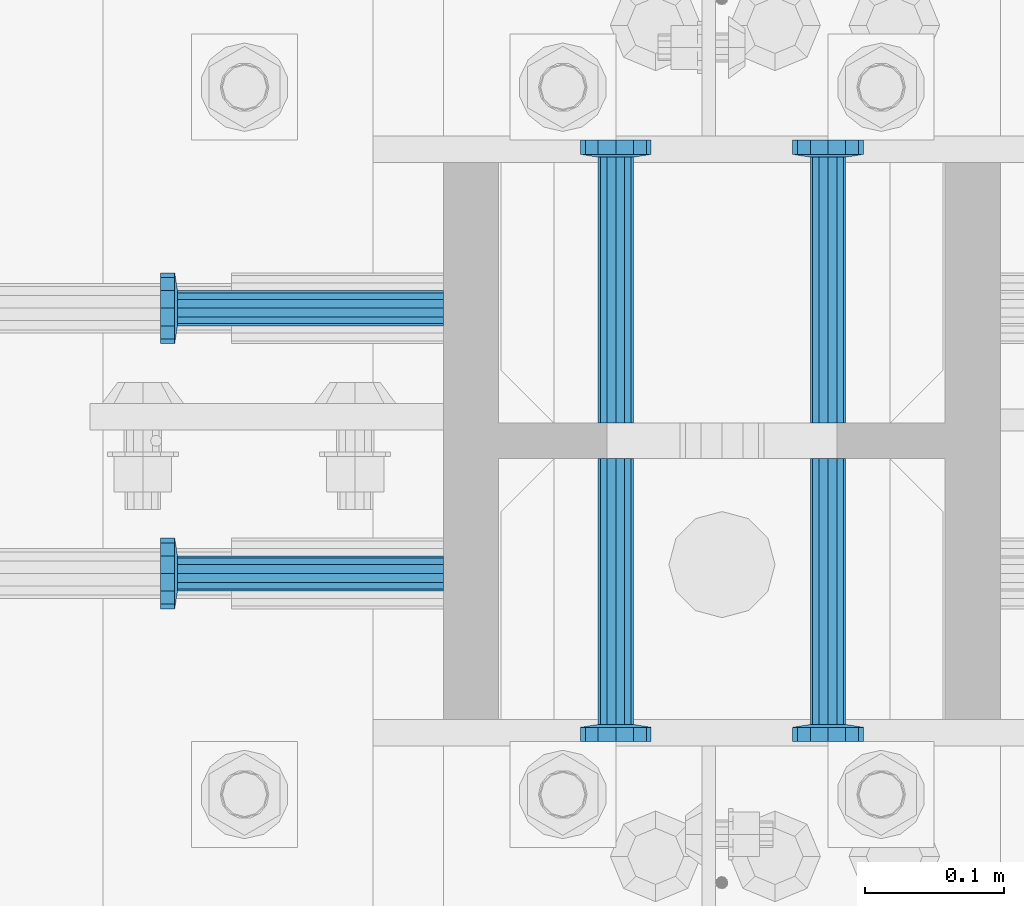
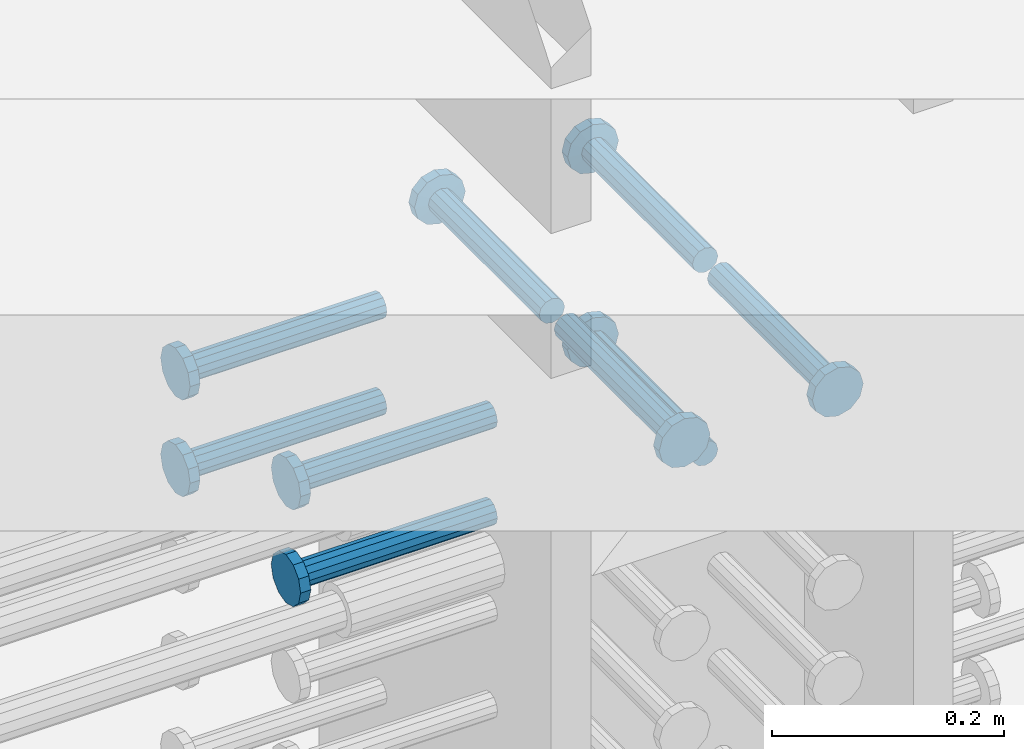
# One storey, part 1189 of 1763: 9 beams, 1 element without a shape of its own.
"""IFC2X3 building model written with IfcOpenShell, lengths in millimetres."""

from ifc_helpers import new_model, si_unit, frame, origin_with_axes, place, context, subcontext, project, spatial, faceted_brep, material, type_object, element, aggregate, save


model = new_model("IFC2X3")

# Units and contexts
model_context = context("Model", 3, precision=1e-05, world=origin_with_axes())
body_context = subcontext(model_context, "Body", "Model", "MODEL_VIEW")
ifc_project = project(units=[si_unit("LENGTHUNIT", "METRE", prefix="MILLI"), si_unit("AREAUNIT", "SQUARE_METRE"), si_unit("VOLUMEUNIT", "CUBIC_METRE"), si_unit("MASSUNIT", "GRAM", prefix="KILO"), si_unit("TIMEUNIT", "SECOND"), si_unit("PLANEANGLEUNIT", "RADIAN"), si_unit("SOLIDANGLEUNIT", "STERADIAN"), si_unit("THERMODYNAMICTEMPERATUREUNIT", "DEGREE_CELSIUS"), si_unit("LUMINOUSINTENSITYUNIT", "LUMEN")], contexts=[model_context])

# Site, building, storey
site_placement = place(None, origin_with_axes())
site = spatial("IfcSite", under=ifc_project, at=site_placement, CompositionType="ELEMENT")
building_placement = place(site_placement, origin_with_axes())
building = spatial("IfcBuilding", under=site, at=building_placement, Name="Undefined", CompositionType="ELEMENT")
storey_placement = place(building_placement, origin_with_axes())
storey = spatial("IfcBuildingStorey", under=building, at=storey_placement, Name="Undefined", CompositionType="ELEMENT", Elevation=0.0)

# Assembly, beams
assembly_placement = place(storey_placement, origin_with_axes())
assembly = element("IfcElementAssembly", 1, at=assembly_placement, inside=storey, Name="COLUMN", AssemblyPlace="NOTDEFINED", PredefinedType="RIGID_FRAME")
ifc_material = material(Name="STEEL/A108")
beam_type = type_object("IfcBeamType", PredefinedType="NOTDEFINED")
beam_1_placement = place(assembly_placement, frame((-72414.8374118345, 469.900000000843, 4927.60000000008), z_axis=(1.0, 0.0, 0.0), x_axis=(0.0, 1.0, 0.0)))
beam_1 = element("IfcBeam", 2, at=beam_1_placement, type_object=beam_type, material=ifc_material, Name="HEADED STUD ANCHOR", context=body_context, shape_type="Brep", body=[
    faceted_brep([(0.0, -12.6999999999971, -1.81898940354586e-12), (3.63797880709171e-12, -11.0, -6.34999990463257), (191.00799999576, -11.0, -6.34999990454889), (191.007999995752, -12.6999998092651, 8.36735125631094e-11), (7.27595761418343e-12, -6.34999990463257, -11.0), (191.00799999576, -6.34999990463257, -10.9999999999163), (3.63797880709171e-12, 0.0, -12.6999998092651), (191.00799999576, 0.0, -12.6999998091815), (7.27595761418343e-12, 6.34999990463257, -11.0), (191.00799999576, 6.34999990463257, -10.9999999999163), (3.63797880709171e-12, 11.0, -6.34999990463257), (191.00799999576, 11.0, -6.34999990454889), (0.0, 12.6999999999971, -1.81898940354586e-12), (191.007999995752, 12.6999998092651, 8.36735125631094e-11), (0.0, 11.0, 6.34999990463257), (191.007999995752, 11.0, 6.34999990471624), (-3.63797880709171e-12, 6.34999990463257, 11.0), (191.007999995749, 6.34999990463257, 11.0000000000837), (-3.63797880709171e-12, 0.0, 12.6999998092651), (191.007999995749, 0.0, 12.6999998093488), (-3.63797880709171e-12, -6.34999990463257, 11.0), (191.007999995749, -6.34999990463257, 11.0000000000837), (0.0, -11.0, 6.34999990463257), (191.007999995752, -11.0, 6.34999990471624), (193.039999995715, -22.0, -12.6999998091796), (193.039999995708, -25.3999996185303, 8.54925019666553e-11), (193.039999995719, -12.6999998092651, -21.9999999999145), (193.039999995719, 0.0, -25.3999996184448), (193.039999995719, 12.6999998092651, -21.9999999999145), (193.039999995715, 22.0, -12.6999998091796), (193.039999995708, 25.3999996185303, 8.54925019666553e-11), (193.039999995704, 22.0, 12.6999998093506), (193.039999995701, 12.6999998092651, 22.0000000000855), (193.039999995697, 0.0, 25.3999996186158), (193.039999995701, -12.6999998092651, 22.0000000000855), (193.039999995704, -22.0, 12.6999998093506), (203.199999995486, -22.0, -12.6999998091742), (203.199999995482, -25.3999996185303, 9.09494701772928e-11), (203.199999995493, -12.6999998092651, -21.9999999999091), (203.199999995493, 0.0, -25.3999996184393), (203.199999995493, 12.6999998092651, -21.9999999999091), (203.199999995486, 22.0, -12.6999998091742), (203.199999995482, 25.3999996185303, 9.09494701772928e-11), (203.199999995479, 22.0, 12.6999998093561), (203.199999995475, 12.6999998092651, 22.0000000000909), (203.199999995471, 0.0, 25.3999996186212), (203.199999995475, -12.6999998092651, 22.0000000000909), (203.199999995479, -22.0, 12.6999998093561)], [[[0, 1, 2, 3]], [[1, 4, 5, 2]], [[4, 6, 7, 5]], [[6, 8, 9, 7]], [[8, 10, 11, 9]], [[10, 12, 13, 11]], [[12, 14, 15, 13]], [[14, 16, 17, 15]], [[16, 18, 19, 17]], [[18, 20, 21, 19]], [[20, 22, 23, 21]], [[22, 0, 3, 23]], [[22, 20, 18, 16, 14, 12, 10, 8, 6, 4, 1, 0]], [[3, 2, 24, 25]], [[2, 5, 26, 24]], [[5, 7, 27, 26]], [[7, 9, 28, 27]], [[9, 11, 29, 28]], [[11, 13, 30, 29]], [[13, 15, 31, 30]], [[15, 17, 32, 31]], [[17, 19, 33, 32]], [[19, 21, 34, 33]], [[21, 23, 35, 34]], [[23, 3, 25, 35]], [[25, 24, 36, 37]], [[24, 26, 38, 36]], [[26, 27, 39, 38]], [[27, 28, 40, 39]], [[28, 29, 41, 40]], [[29, 30, 42, 41]], [[30, 31, 43, 42]], [[31, 32, 44, 43]], [[32, 33, 45, 44]], [[33, 34, 46, 45]], [[34, 35, 47, 46]], [[35, 25, 37, 47]], [[38, 39, 40, 41, 42, 43, 44, 45, 46, 47, 37, 36]]]),
])
beam_2_placement = place(assembly_placement, frame((-72567.2374118343, 469.899999003702, 4927.60000000008), z_axis=(1.0, 0.0, 0.0), x_axis=(0.0, 1.0, 0.0)))
beam_2 = element("IfcBeam", 3, at=beam_2_placement, type_object=beam_type, material=ifc_material, Name="HEADED STUD ANCHOR", context=body_context, shape_type="Brep", body=[
    faceted_brep([(0.0, -12.6999999999971, -1.81898940354586e-12), (3.63797880709171e-12, -11.0, -6.34999990463257), (191.00799999576, -11.0, -6.34999990454889), (191.007999995752, -12.6999998092651, 8.36735125631094e-11), (7.27595761418343e-12, -6.34999990463257, -11.0), (191.00799999576, -6.34999990463257, -10.9999999999163), (3.63797880709171e-12, 0.0, -12.6999998092651), (191.00799999576, 0.0, -12.6999998091815), (7.27595761418343e-12, 6.34999990463257, -11.0), (191.00799999576, 6.34999990463257, -10.9999999999163), (3.63797880709171e-12, 11.0, -6.34999990463257), (191.00799999576, 11.0, -6.34999990454889), (0.0, 12.6999999999971, -1.81898940354586e-12), (191.007999995752, 12.6999998092651, 8.36735125631094e-11), (0.0, 11.0, 6.34999990463257), (191.007999995752, 11.0, 6.34999990471624), (-3.63797880709171e-12, 6.34999990463257, 11.0), (191.007999995749, 6.34999990463257, 11.0000000000837), (-3.63797880709171e-12, 0.0, 12.6999998092651), (191.007999995749, 0.0, 12.6999998093488), (-3.63797880709171e-12, -6.34999990463257, 11.0), (191.007999995749, -6.34999990463257, 11.0000000000837), (0.0, -11.0, 6.34999990463257), (191.007999995752, -11.0, 6.34999990471624), (193.039999995715, -22.0, -12.6999998091796), (193.039999995708, -25.3999996185303, 8.54925019666553e-11), (193.039999995719, -12.6999998092651, -21.9999999999145), (193.039999995719, 0.0, -25.3999996184448), (193.039999995719, 12.6999998092651, -21.9999999999145), (193.039999995715, 22.0, -12.6999998091796), (193.039999995708, 25.3999996185303, 8.54925019666553e-11), (193.039999995704, 22.0, 12.6999998093506), (193.039999995701, 12.6999998092651, 22.0000000000855), (193.039999995697, 0.0, 25.3999996186158), (193.039999995701, -12.6999998092651, 22.0000000000855), (193.039999995704, -22.0, 12.6999998093506), (203.199999995486, -22.0, -12.6999998091742), (203.199999995482, -25.3999996185303, 9.09494701772928e-11), (203.199999995493, -12.6999998092651, -21.9999999999091), (203.199999995493, 0.0, -25.3999996184393), (203.199999995493, 12.6999998092651, -21.9999999999091), (203.199999995486, 22.0, -12.6999998091742), (203.199999995482, 25.3999996185303, 9.09494701772928e-11), (203.199999995479, 22.0, 12.6999998093561), (203.199999995475, 12.6999998092651, 22.0000000000909), (203.199999995471, 0.0, 25.3999996186212), (203.199999995475, -12.6999998092651, 22.0000000000909), (203.199999995479, -22.0, 12.6999998093561)], [[[0, 1, 2, 3]], [[1, 4, 5, 2]], [[4, 6, 7, 5]], [[6, 8, 9, 7]], [[8, 10, 11, 9]], [[10, 12, 13, 11]], [[12, 14, 15, 13]], [[14, 16, 17, 15]], [[16, 18, 19, 17]], [[18, 20, 21, 19]], [[20, 22, 23, 21]], [[22, 0, 3, 23]], [[22, 20, 18, 16, 14, 12, 10, 8, 6, 4, 1, 0]], [[3, 2, 24, 25]], [[2, 5, 26, 24]], [[5, 7, 27, 26]], [[7, 9, 28, 27]], [[9, 11, 29, 28]], [[11, 13, 30, 29]], [[13, 15, 31, 30]], [[15, 17, 32, 31]], [[17, 19, 33, 32]], [[19, 21, 34, 33]], [[21, 23, 35, 34]], [[23, 3, 25, 35]], [[25, 24, 36, 37]], [[24, 26, 38, 36]], [[26, 27, 39, 38]], [[27, 28, 40, 39]], [[28, 29, 41, 40]], [[29, 30, 42, 41]], [[30, 31, 43, 42]], [[31, 32, 44, 43]], [[32, 33, 45, 44]], [[33, 34, 46, 45]], [[34, 35, 47, 46]], [[35, 25, 37, 47]], [[38, 39, 40, 41, 42, 43, 44, 45, 46, 47, 37, 36]]]),
])
beam_3_placement = place(assembly_placement, frame((-72691.0622736972, 552.45000000066, 4927.60000000008), z_axis=(0.0, 1.0, 0.0), x_axis=(-1.0, 0.0, 0.0)))
beam_3 = element("IfcBeam", 4, at=beam_3_placement, type_object=beam_type, material=ifc_material, Name="HEADED STUD ANCHOR", context=body_context, shape_type="Brep", body=[
    faceted_brep([(0.0, -12.6999999999971, -1.81898940354586e-12), (3.63797880709171e-12, -11.0, -6.34999990463257), (191.00799999576, -11.0, -6.34999990454889), (191.007999995752, -12.6999998092651, 8.36735125631094e-11), (7.27595761418343e-12, -6.34999990463257, -11.0), (191.00799999576, -6.34999990463257, -10.9999999999163), (3.63797880709171e-12, 0.0, -12.6999998092651), (191.00799999576, 0.0, -12.6999998091815), (7.27595761418343e-12, 6.34999990463257, -11.0), (191.00799999576, 6.34999990463257, -10.9999999999163), (3.63797880709171e-12, 11.0, -6.34999990463257), (191.00799999576, 11.0, -6.34999990454889), (0.0, 12.6999999999971, -1.81898940354586e-12), (191.007999995752, 12.6999998092651, 8.36735125631094e-11), (0.0, 11.0, 6.34999990463257), (191.007999995752, 11.0, 6.34999990471624), (-3.63797880709171e-12, 6.34999990463257, 11.0), (191.007999995749, 6.34999990463257, 11.0000000000837), (-3.63797880709171e-12, 0.0, 12.6999998092651), (191.007999995749, 0.0, 12.6999998093488), (-3.63797880709171e-12, -6.34999990463257, 11.0), (191.007999995749, -6.34999990463257, 11.0000000000837), (0.0, -11.0, 6.34999990463257), (191.007999995752, -11.0, 6.34999990471624), (193.039999995715, -22.0, -12.6999998091796), (193.039999995708, -25.3999996185303, 8.54925019666553e-11), (193.039999995719, -12.6999998092651, -21.9999999999145), (193.039999995719, 0.0, -25.3999996184448), (193.039999995719, 12.6999998092651, -21.9999999999145), (193.039999995715, 22.0, -12.6999998091796), (193.039999995708, 25.3999996185303, 8.54925019666553e-11), (193.039999995704, 22.0, 12.6999998093506), (193.039999995701, 12.6999998092651, 22.0000000000855), (193.039999995697, 0.0, 25.3999996186158), (193.039999995701, -12.6999998092651, 22.0000000000855), (193.039999995704, -22.0, 12.6999998093506), (203.199999995486, -22.0, -12.6999998091742), (203.199999995482, -25.3999996185303, 9.09494701772928e-11), (203.199999995493, -12.6999998092651, -21.9999999999091), (203.199999995493, 0.0, -25.3999996184393), (203.199999995493, 12.6999998092651, -21.9999999999091), (203.199999995486, 22.0, -12.6999998091742), (203.199999995482, 25.3999996185303, 9.09494701772928e-11), (203.199999995479, 22.0, 12.6999998093561), (203.199999995475, 12.6999998092651, 22.0000000000909), (203.199999995471, 0.0, 25.3999996186212), (203.199999995475, -12.6999998092651, 22.0000000000909), (203.199999995479, -22.0, 12.6999998093561)], [[[0, 1, 2, 3]], [[1, 4, 5, 2]], [[4, 6, 7, 5]], [[6, 8, 9, 7]], [[8, 10, 11, 9]], [[10, 12, 13, 11]], [[12, 14, 15, 13]], [[14, 16, 17, 15]], [[16, 18, 19, 17]], [[18, 20, 21, 19]], [[20, 22, 23, 21]], [[22, 0, 3, 23]], [[22, 20, 18, 16, 14, 12, 10, 8, 6, 4, 1, 0]], [[3, 2, 24, 25]], [[2, 5, 26, 24]], [[5, 7, 27, 26]], [[7, 9, 28, 27]], [[9, 11, 29, 28]], [[11, 13, 30, 29]], [[13, 15, 31, 30]], [[15, 17, 32, 31]], [[17, 19, 33, 32]], [[19, 21, 34, 33]], [[21, 23, 35, 34]], [[23, 3, 25, 35]], [[25, 24, 36, 37]], [[24, 26, 38, 36]], [[26, 27, 39, 38]], [[27, 28, 40, 39]], [[28, 29, 41, 40]], [[29, 30, 42, 41]], [[30, 31, 43, 42]], [[31, 32, 44, 43]], [[32, 33, 45, 44]], [[33, 34, 46, 45]], [[34, 35, 47, 46]], [[35, 25, 37, 47]], [[38, 39, 40, 41, 42, 43, 44, 45, 46, 47, 37, 36]]]),
])
beam_4_placement = place(assembly_placement, frame((-72691.0623424328, 361.950000000834, 4927.60000000008), z_axis=(0.0, 1.0, 0.0), x_axis=(-1.0, 0.0, 0.0)))
beam_4 = element("IfcBeam", 5, at=beam_4_placement, type_object=beam_type, material=ifc_material, Name="HEADED STUD ANCHOR", context=body_context, shape_type="Brep", body=[
    faceted_brep([(0.0, -12.6999999999971, -1.81898940354586e-12), (3.63797880709171e-12, -11.0, -6.34999990463257), (191.00799999576, -11.0, -6.34999990454889), (191.007999995752, -12.6999998092651, 8.36735125631094e-11), (7.27595761418343e-12, -6.34999990463257, -11.0), (191.00799999576, -6.34999990463257, -10.9999999999163), (3.63797880709171e-12, 0.0, -12.6999998092651), (191.00799999576, 0.0, -12.6999998091815), (7.27595761418343e-12, 6.34999990463257, -11.0), (191.00799999576, 6.34999990463257, -10.9999999999163), (3.63797880709171e-12, 11.0, -6.34999990463257), (191.00799999576, 11.0, -6.34999990454889), (0.0, 12.6999999999971, -1.81898940354586e-12), (191.007999995752, 12.6999998092651, 8.36735125631094e-11), (0.0, 11.0, 6.34999990463257), (191.007999995752, 11.0, 6.34999990471624), (-3.63797880709171e-12, 6.34999990463257, 11.0), (191.007999995749, 6.34999990463257, 11.0000000000837), (-3.63797880709171e-12, 0.0, 12.6999998092651), (191.007999995749, 0.0, 12.6999998093488), (-3.63797880709171e-12, -6.34999990463257, 11.0), (191.007999995749, -6.34999990463257, 11.0000000000837), (0.0, -11.0, 6.34999990463257), (191.007999995752, -11.0, 6.34999990471624), (193.039999995715, -22.0, -12.6999998091796), (193.039999995708, -25.3999996185303, 8.54925019666553e-11), (193.039999995719, -12.6999998092651, -21.9999999999145), (193.039999995719, 0.0, -25.3999996184448), (193.039999995719, 12.6999998092651, -21.9999999999145), (193.039999995715, 22.0, -12.6999998091796), (193.039999995708, 25.3999996185303, 8.54925019666553e-11), (193.039999995704, 22.0, 12.6999998093506), (193.039999995701, 12.6999998092651, 22.0000000000855), (193.039999995697, 0.0, 25.3999996186158), (193.039999995701, -12.6999998092651, 22.0000000000855), (193.039999995704, -22.0, 12.6999998093506), (203.199999995486, -22.0, -12.6999998091742), (203.199999995482, -25.3999996185303, 9.09494701772928e-11), (203.199999995493, -12.6999998092651, -21.9999999999091), (203.199999995493, 0.0, -25.3999996184393), (203.199999995493, 12.6999998092651, -21.9999999999091), (203.199999995486, 22.0, -12.6999998091742), (203.199999995482, 25.3999996185303, 9.09494701772928e-11), (203.199999995479, 22.0, 12.6999998093561), (203.199999995475, 12.6999998092651, 22.0000000000909), (203.199999995471, 0.0, 25.3999996186212), (203.199999995475, -12.6999998092651, 22.0000000000909), (203.199999995479, -22.0, 12.6999998093561)], [[[0, 1, 2, 3]], [[1, 4, 5, 2]], [[4, 6, 7, 5]], [[6, 8, 9, 7]], [[8, 10, 11, 9]], [[10, 12, 13, 11]], [[12, 14, 15, 13]], [[14, 16, 17, 15]], [[16, 18, 19, 17]], [[18, 20, 21, 19]], [[20, 22, 23, 21]], [[22, 0, 3, 23]], [[22, 20, 18, 16, 14, 12, 10, 8, 6, 4, 1, 0]], [[3, 2, 24, 25]], [[2, 5, 26, 24]], [[5, 7, 27, 26]], [[7, 9, 28, 27]], [[9, 11, 29, 28]], [[11, 13, 30, 29]], [[13, 15, 31, 30]], [[15, 17, 32, 31]], [[17, 19, 33, 32]], [[19, 21, 34, 33]], [[21, 23, 35, 34]], [[23, 3, 25, 35]], [[25, 24, 36, 37]], [[24, 26, 38, 36]], [[26, 27, 39, 38]], [[27, 28, 40, 39]], [[28, 29, 41, 40]], [[29, 30, 42, 41]], [[30, 31, 43, 42]], [[31, 32, 44, 43]], [[32, 33, 45, 44]], [[33, 34, 46, 45]], [[34, 35, 47, 46]], [[35, 25, 37, 47]], [[38, 39, 40, 41, 42, 43, 44, 45, 46, 47, 37, 36]]]),
])
beam_5_placement = place(assembly_placement, frame((-72567.2374108258, 444.499999886566, 4927.60000000008), z_axis=(1.0, 0.0, 0.0), x_axis=(0.0, -1.0, 0.0)))
beam_5 = element("IfcBeam", 6, at=beam_5_placement, type_object=beam_type, material=ifc_material, Name="HEADED STUD ANCHOR", context=body_context, shape_type="Brep", body=[
    faceted_brep([(0.0, -12.6999999999971, -1.81898940354586e-12), (3.63797880709171e-12, -11.0, -6.34999990463257), (191.00799999576, -11.0, -6.34999990454889), (191.007999995752, -12.6999998092651, 8.36735125631094e-11), (7.27595761418343e-12, -6.34999990463257, -11.0), (191.00799999576, -6.34999990463257, -10.9999999999163), (3.63797880709171e-12, 0.0, -12.6999998092651), (191.00799999576, 0.0, -12.6999998091815), (7.27595761418343e-12, 6.34999990463257, -11.0), (191.00799999576, 6.34999990463257, -10.9999999999163), (3.63797880709171e-12, 11.0, -6.34999990463257), (191.00799999576, 11.0, -6.34999990454889), (0.0, 12.6999999999971, -1.81898940354586e-12), (191.007999995752, 12.6999998092651, 8.36735125631094e-11), (0.0, 11.0, 6.34999990463257), (191.007999995752, 11.0, 6.34999990471624), (-3.63797880709171e-12, 6.34999990463257, 11.0), (191.007999995749, 6.34999990463257, 11.0000000000837), (-3.63797880709171e-12, 0.0, 12.6999998092651), (191.007999995749, 0.0, 12.6999998093488), (-3.63797880709171e-12, -6.34999990463257, 11.0), (191.007999995749, -6.34999990463257, 11.0000000000837), (0.0, -11.0, 6.34999990463257), (191.007999995752, -11.0, 6.34999990471624), (193.039999995715, -22.0, -12.6999998091796), (193.039999995708, -25.3999996185303, 8.54925019666553e-11), (193.039999995719, -12.6999998092651, -21.9999999999145), (193.039999995719, 0.0, -25.3999996184448), (193.039999995719, 12.6999998092651, -21.9999999999145), (193.039999995715, 22.0, -12.6999998091796), (193.039999995708, 25.3999996185303, 8.54925019666553e-11), (193.039999995704, 22.0, 12.6999998093506), (193.039999995701, 12.6999998092651, 22.0000000000855), (193.039999995697, 0.0, 25.3999996186158), (193.039999995701, -12.6999998092651, 22.0000000000855), (193.039999995704, -22.0, 12.6999998093506), (203.199999995486, -22.0, -12.6999998091742), (203.199999995482, -25.3999996185303, 9.09494701772928e-11), (203.199999995493, -12.6999998092651, -21.9999999999091), (203.199999995493, 0.0, -25.3999996184393), (203.199999995493, 12.6999998092651, -21.9999999999091), (203.199999995486, 22.0, -12.6999998091742), (203.199999995482, 25.3999996185303, 9.09494701772928e-11), (203.199999995479, 22.0, 12.6999998093561), (203.199999995475, 12.6999998092651, 22.0000000000909), (203.199999995471, 0.0, 25.3999996186212), (203.199999995475, -12.6999998092651, 22.0000000000909), (203.199999995479, -22.0, 12.6999998093561)], [[[0, 1, 2, 3]], [[1, 4, 5, 2]], [[4, 6, 7, 5]], [[6, 8, 9, 7]], [[8, 10, 11, 9]], [[10, 12, 13, 11]], [[12, 14, 15, 13]], [[14, 16, 17, 15]], [[16, 18, 19, 17]], [[18, 20, 21, 19]], [[20, 22, 23, 21]], [[22, 0, 3, 23]], [[22, 20, 18, 16, 14, 12, 10, 8, 6, 4, 1, 0]], [[3, 2, 24, 25]], [[2, 5, 26, 24]], [[5, 7, 27, 26]], [[7, 9, 28, 27]], [[9, 11, 29, 28]], [[11, 13, 30, 29]], [[13, 15, 31, 30]], [[15, 17, 32, 31]], [[17, 19, 33, 32]], [[19, 21, 34, 33]], [[21, 23, 35, 34]], [[23, 3, 25, 35]], [[25, 24, 36, 37]], [[24, 26, 38, 36]], [[26, 27, 39, 38]], [[27, 28, 40, 39]], [[28, 29, 41, 40]], [[29, 30, 42, 41]], [[30, 31, 43, 42]], [[31, 32, 44, 43]], [[32, 33, 45, 44]], [[33, 34, 46, 45]], [[34, 35, 47, 46]], [[35, 25, 37, 47]], [[38, 39, 40, 41, 42, 43, 44, 45, 46, 47, 37, 36]]]),
])
beam_6_placement = place(assembly_placement, frame((-72414.8374108267, 444.500000000843, 4927.60000000008), z_axis=(1.0, 0.0, 0.0), x_axis=(0.0, -1.0, 0.0)))
beam_6 = element("IfcBeam", 7, at=beam_6_placement, type_object=beam_type, material=ifc_material, Name="HEADED STUD ANCHOR", context=body_context, shape_type="Brep", body=[
    faceted_brep([(0.0, -12.6999999999971, -1.81898940354586e-12), (3.63797880709171e-12, -11.0, -6.34999990463257), (191.00799999576, -11.0, -6.34999990454889), (191.007999995752, -12.6999998092651, 8.36735125631094e-11), (7.27595761418343e-12, -6.34999990463257, -11.0), (191.00799999576, -6.34999990463257, -10.9999999999163), (3.63797880709171e-12, 0.0, -12.6999998092651), (191.00799999576, 0.0, -12.6999998091815), (7.27595761418343e-12, 6.34999990463257, -11.0), (191.00799999576, 6.34999990463257, -10.9999999999163), (3.63797880709171e-12, 11.0, -6.34999990463257), (191.00799999576, 11.0, -6.34999990454889), (0.0, 12.6999999999971, -1.81898940354586e-12), (191.007999995752, 12.6999998092651, 8.36735125631094e-11), (0.0, 11.0, 6.34999990463257), (191.007999995752, 11.0, 6.34999990471624), (-3.63797880709171e-12, 6.34999990463257, 11.0), (191.007999995749, 6.34999990463257, 11.0000000000837), (-3.63797880709171e-12, 0.0, 12.6999998092651), (191.007999995749, 0.0, 12.6999998093488), (-3.63797880709171e-12, -6.34999990463257, 11.0), (191.007999995749, -6.34999990463257, 11.0000000000837), (0.0, -11.0, 6.34999990463257), (191.007999995752, -11.0, 6.34999990471624), (193.039999995715, -22.0, -12.6999998091796), (193.039999995708, -25.3999996185303, 8.54925019666553e-11), (193.039999995719, -12.6999998092651, -21.9999999999145), (193.039999995719, 0.0, -25.3999996184448), (193.039999995719, 12.6999998092651, -21.9999999999145), (193.039999995715, 22.0, -12.6999998091796), (193.039999995708, 25.3999996185303, 8.54925019666553e-11), (193.039999995704, 22.0, 12.6999998093506), (193.039999995701, 12.6999998092651, 22.0000000000855), (193.039999995697, 0.0, 25.3999996186158), (193.039999995701, -12.6999998092651, 22.0000000000855), (193.039999995704, -22.0, 12.6999998093506), (203.199999995486, -22.0, -12.6999998091742), (203.199999995482, -25.3999996185303, 9.09494701772928e-11), (203.199999995493, -12.6999998092651, -21.9999999999091), (203.199999995493, 0.0, -25.3999996184393), (203.199999995493, 12.6999998092651, -21.9999999999091), (203.199999995486, 22.0, -12.6999998091742), (203.199999995482, 25.3999996185303, 9.09494701772928e-11), (203.199999995479, 22.0, 12.6999998093561), (203.199999995475, 12.6999998092651, 22.0000000000909), (203.199999995471, 0.0, 25.3999996186212), (203.199999995475, -12.6999998092651, 22.0000000000909), (203.199999995479, -22.0, 12.6999998093561)], [[[0, 1, 2, 3]], [[1, 4, 5, 2]], [[4, 6, 7, 5]], [[6, 8, 9, 7]], [[8, 10, 11, 9]], [[10, 12, 13, 11]], [[12, 14, 15, 13]], [[14, 16, 17, 15]], [[16, 18, 19, 17]], [[18, 20, 21, 19]], [[20, 22, 23, 21]], [[22, 0, 3, 23]], [[22, 20, 18, 16, 14, 12, 10, 8, 6, 4, 1, 0]], [[3, 2, 24, 25]], [[2, 5, 26, 24]], [[5, 7, 27, 26]], [[7, 9, 28, 27]], [[9, 11, 29, 28]], [[11, 13, 30, 29]], [[13, 15, 31, 30]], [[15, 17, 32, 31]], [[17, 19, 33, 32]], [[19, 21, 34, 33]], [[21, 23, 35, 34]], [[23, 3, 25, 35]], [[25, 24, 36, 37]], [[24, 26, 38, 36]], [[26, 27, 39, 38]], [[27, 28, 40, 39]], [[28, 29, 41, 40]], [[29, 30, 42, 41]], [[30, 31, 43, 42]], [[31, 32, 44, 43]], [[32, 33, 45, 44]], [[33, 34, 46, 45]], [[34, 35, 47, 46]], [[35, 25, 37, 47]], [[38, 39, 40, 41, 42, 43, 44, 45, 46, 47, 37, 36]]]),
])
beam_7_placement = place(assembly_placement, frame((-72691.0622049617, 552.45000000066, 4826.00000000007), z_axis=(0.0, 1.0, 0.0), x_axis=(-1.0, 0.0, 0.0)))
beam_7 = element("IfcBeam", 8, at=beam_7_placement, type_object=beam_type, material=ifc_material, Name="HEADED STUD ANCHOR", context=body_context, shape_type="Brep", body=[
    faceted_brep([(0.0, -12.6999999999971, -1.81898940354586e-12), (3.63797880709171e-12, -11.0, -6.34999990463257), (191.00799999576, -11.0, -6.34999990454889), (191.007999995752, -12.6999998092651, 8.36735125631094e-11), (7.27595761418343e-12, -6.34999990463257, -11.0), (191.00799999576, -6.34999990463257, -10.9999999999163), (3.63797880709171e-12, 0.0, -12.6999998092651), (191.00799999576, 0.0, -12.6999998091815), (7.27595761418343e-12, 6.34999990463257, -11.0), (191.00799999576, 6.34999990463257, -10.9999999999163), (3.63797880709171e-12, 11.0, -6.34999990463257), (191.00799999576, 11.0, -6.34999990454889), (0.0, 12.6999999999971, -1.81898940354586e-12), (191.007999995752, 12.6999998092651, 8.36735125631094e-11), (0.0, 11.0, 6.34999990463257), (191.007999995752, 11.0, 6.34999990471624), (-3.63797880709171e-12, 6.34999990463257, 11.0), (191.007999995749, 6.34999990463257, 11.0000000000837), (-3.63797880709171e-12, 0.0, 12.6999998092651), (191.007999995749, 0.0, 12.6999998093488), (-3.63797880709171e-12, -6.34999990463257, 11.0), (191.007999995749, -6.34999990463257, 11.0000000000837), (0.0, -11.0, 6.34999990463257), (191.007999995752, -11.0, 6.34999990471624), (193.039999995715, -22.0, -12.6999998091796), (193.039999995708, -25.3999996185303, 8.54925019666553e-11), (193.039999995719, -12.6999998092651, -21.9999999999145), (193.039999995719, 0.0, -25.3999996184448), (193.039999995719, 12.6999998092651, -21.9999999999145), (193.039999995715, 22.0, -12.6999998091796), (193.039999995708, 25.3999996185303, 8.54925019666553e-11), (193.039999995704, 22.0, 12.6999998093506), (193.039999995701, 12.6999998092651, 22.0000000000855), (193.039999995697, 0.0, 25.3999996186158), (193.039999995701, -12.6999998092651, 22.0000000000855), (193.039999995704, -22.0, 12.6999998093506), (203.199999995486, -22.0, -12.6999998091742), (203.199999995482, -25.3999996185303, 9.09494701772928e-11), (203.199999995493, -12.6999998092651, -21.9999999999091), (203.199999995493, 0.0, -25.3999996184393), (203.199999995493, 12.6999998092651, -21.9999999999091), (203.199999995486, 22.0, -12.6999998091742), (203.199999995482, 25.3999996185303, 9.09494701772928e-11), (203.199999995479, 22.0, 12.6999998093561), (203.199999995475, 12.6999998092651, 22.0000000000909), (203.199999995471, 0.0, 25.3999996186212), (203.199999995475, -12.6999998092651, 22.0000000000909), (203.199999995479, -22.0, 12.6999998093561)], [[[0, 1, 2, 3]], [[1, 4, 5, 2]], [[4, 6, 7, 5]], [[6, 8, 9, 7]], [[8, 10, 11, 9]], [[10, 12, 13, 11]], [[12, 14, 15, 13]], [[14, 16, 17, 15]], [[16, 18, 19, 17]], [[18, 20, 21, 19]], [[20, 22, 23, 21]], [[22, 0, 3, 23]], [[22, 20, 18, 16, 14, 12, 10, 8, 6, 4, 1, 0]], [[3, 2, 24, 25]], [[2, 5, 26, 24]], [[5, 7, 27, 26]], [[7, 9, 28, 27]], [[9, 11, 29, 28]], [[11, 13, 30, 29]], [[13, 15, 31, 30]], [[15, 17, 32, 31]], [[17, 19, 33, 32]], [[19, 21, 34, 33]], [[21, 23, 35, 34]], [[23, 3, 25, 35]], [[25, 24, 36, 37]], [[24, 26, 38, 36]], [[26, 27, 39, 38]], [[27, 28, 40, 39]], [[28, 29, 41, 40]], [[29, 30, 42, 41]], [[30, 31, 43, 42]], [[31, 32, 44, 43]], [[32, 33, 45, 44]], [[33, 34, 46, 45]], [[34, 35, 47, 46]], [[35, 25, 37, 47]], [[38, 39, 40, 41, 42, 43, 44, 45, 46, 47, 37, 36]]]),
])
beam_8_placement = place(assembly_placement, frame((-72691.0622736973, 361.950000000834, 4826.00000000007), z_axis=(0.0, 1.0, 0.0), x_axis=(-1.0, 0.0, 0.0)))
beam_8 = element("IfcBeam", 9, at=beam_8_placement, type_object=beam_type, material=ifc_material, Name="HEADED STUD ANCHOR", context=body_context, shape_type="Brep", body=[
    faceted_brep([(0.0, -12.6999999999971, -1.81898940354586e-12), (3.63797880709171e-12, -11.0, -6.34999990463257), (191.00799999576, -11.0, -6.34999990454889), (191.007999995752, -12.6999998092651, 8.36735125631094e-11), (7.27595761418343e-12, -6.34999990463257, -11.0), (191.00799999576, -6.34999990463257, -10.9999999999163), (3.63797880709171e-12, 0.0, -12.6999998092651), (191.00799999576, 0.0, -12.6999998091815), (7.27595761418343e-12, 6.34999990463257, -11.0), (191.00799999576, 6.34999990463257, -10.9999999999163), (3.63797880709171e-12, 11.0, -6.34999990463257), (191.00799999576, 11.0, -6.34999990454889), (0.0, 12.6999999999971, -1.81898940354586e-12), (191.007999995752, 12.6999998092651, 8.36735125631094e-11), (0.0, 11.0, 6.34999990463257), (191.007999995752, 11.0, 6.34999990471624), (-3.63797880709171e-12, 6.34999990463257, 11.0), (191.007999995749, 6.34999990463257, 11.0000000000837), (-3.63797880709171e-12, 0.0, 12.6999998092651), (191.007999995749, 0.0, 12.6999998093488), (-3.63797880709171e-12, -6.34999990463257, 11.0), (191.007999995749, -6.34999990463257, 11.0000000000837), (0.0, -11.0, 6.34999990463257), (191.007999995752, -11.0, 6.34999990471624), (193.039999995715, -22.0, -12.6999998091796), (193.039999995708, -25.3999996185303, 8.54925019666553e-11), (193.039999995719, -12.6999998092651, -21.9999999999145), (193.039999995719, 0.0, -25.3999996184448), (193.039999995719, 12.6999998092651, -21.9999999999145), (193.039999995715, 22.0, -12.6999998091796), (193.039999995708, 25.3999996185303, 8.54925019666553e-11), (193.039999995704, 22.0, 12.6999998093506), (193.039999995701, 12.6999998092651, 22.0000000000855), (193.039999995697, 0.0, 25.3999996186158), (193.039999995701, -12.6999998092651, 22.0000000000855), (193.039999995704, -22.0, 12.6999998093506), (203.199999995486, -22.0, -12.6999998091742), (203.199999995482, -25.3999996185303, 9.09494701772928e-11), (203.199999995493, -12.6999998092651, -21.9999999999091), (203.199999995493, 0.0, -25.3999996184393), (203.199999995493, 12.6999998092651, -21.9999999999091), (203.199999995486, 22.0, -12.6999998091742), (203.199999995482, 25.3999996185303, 9.09494701772928e-11), (203.199999995479, 22.0, 12.6999998093561), (203.199999995475, 12.6999998092651, 22.0000000000909), (203.199999995471, 0.0, 25.3999996186212), (203.199999995475, -12.6999998092651, 22.0000000000909), (203.199999995479, -22.0, 12.6999998093561)], [[[0, 1, 2, 3]], [[1, 4, 5, 2]], [[4, 6, 7, 5]], [[6, 8, 9, 7]], [[8, 10, 11, 9]], [[10, 12, 13, 11]], [[12, 14, 15, 13]], [[14, 16, 17, 15]], [[16, 18, 19, 17]], [[18, 20, 21, 19]], [[20, 22, 23, 21]], [[22, 0, 3, 23]], [[22, 20, 18, 16, 14, 12, 10, 8, 6, 4, 1, 0]], [[3, 2, 24, 25]], [[2, 5, 26, 24]], [[5, 7, 27, 26]], [[7, 9, 28, 27]], [[9, 11, 29, 28]], [[11, 13, 30, 29]], [[13, 15, 31, 30]], [[15, 17, 32, 31]], [[17, 19, 33, 32]], [[19, 21, 34, 33]], [[21, 23, 35, 34]], [[23, 3, 25, 35]], [[25, 24, 36, 37]], [[24, 26, 38, 36]], [[26, 27, 39, 38]], [[27, 28, 40, 39]], [[28, 29, 41, 40]], [[29, 30, 42, 41]], [[30, 31, 43, 42]], [[31, 32, 44, 43]], [[32, 33, 45, 44]], [[33, 34, 46, 45]], [[34, 35, 47, 46]], [[35, 25, 37, 47]], [[38, 39, 40, 41, 42, 43, 44, 45, 46, 47, 37, 36]]]),
])
beam_9_placement = place(assembly_placement, frame((-72414.837343099, 469.900000000843, 4724.40000000007), z_axis=(1.0, 0.0, 0.0), x_axis=(0.0, 1.0, 0.0)))
beam_9 = element("IfcBeam", 10, at=beam_9_placement, type_object=beam_type, material=ifc_material, Name="HEADED STUD ANCHOR", context=body_context, shape_type="Brep", body=[
    faceted_brep([(0.0, -12.6999999999971, -1.81898940354586e-12), (3.63797880709171e-12, -11.0, -6.34999990463257), (191.00799999576, -11.0, -6.34999990454889), (191.007999995752, -12.6999998092651, 8.36735125631094e-11), (7.27595761418343e-12, -6.34999990463257, -11.0), (191.00799999576, -6.34999990463257, -10.9999999999163), (3.63797880709171e-12, 0.0, -12.6999998092651), (191.00799999576, 0.0, -12.6999998091815), (7.27595761418343e-12, 6.34999990463257, -11.0), (191.00799999576, 6.34999990463257, -10.9999999999163), (3.63797880709171e-12, 11.0, -6.34999990463257), (191.00799999576, 11.0, -6.34999990454889), (0.0, 12.6999999999971, -1.81898940354586e-12), (191.007999995752, 12.6999998092651, 8.36735125631094e-11), (0.0, 11.0, 6.34999990463257), (191.007999995752, 11.0, 6.34999990471624), (-3.63797880709171e-12, 6.34999990463257, 11.0), (191.007999995749, 6.34999990463257, 11.0000000000837), (-3.63797880709171e-12, 0.0, 12.6999998092651), (191.007999995749, 0.0, 12.6999998093488), (-3.63797880709171e-12, -6.34999990463257, 11.0), (191.007999995749, -6.34999990463257, 11.0000000000837), (0.0, -11.0, 6.34999990463257), (191.007999995752, -11.0, 6.34999990471624), (193.039999995715, -22.0, -12.6999998091796), (193.039999995708, -25.3999996185303, 8.54925019666553e-11), (193.039999995719, -12.6999998092651, -21.9999999999145), (193.039999995719, 0.0, -25.3999996184448), (193.039999995719, 12.6999998092651, -21.9999999999145), (193.039999995715, 22.0, -12.6999998091796), (193.039999995708, 25.3999996185303, 8.54925019666553e-11), (193.039999995704, 22.0, 12.6999998093506), (193.039999995701, 12.6999998092651, 22.0000000000855), (193.039999995697, 0.0, 25.3999996186158), (193.039999995701, -12.6999998092651, 22.0000000000855), (193.039999995704, -22.0, 12.6999998093506), (203.199999995486, -22.0, -12.6999998091742), (203.199999995482, -25.3999996185303, 9.09494701772928e-11), (203.199999995493, -12.6999998092651, -21.9999999999091), (203.199999995493, 0.0, -25.3999996184393), (203.199999995493, 12.6999998092651, -21.9999999999091), (203.199999995486, 22.0, -12.6999998091742), (203.199999995482, 25.3999996185303, 9.09494701772928e-11), (203.199999995479, 22.0, 12.6999998093561), (203.199999995475, 12.6999998092651, 22.0000000000909), (203.199999995471, 0.0, 25.3999996186212), (203.199999995475, -12.6999998092651, 22.0000000000909), (203.199999995479, -22.0, 12.6999998093561)], [[[0, 1, 2, 3]], [[1, 4, 5, 2]], [[4, 6, 7, 5]], [[6, 8, 9, 7]], [[8, 10, 11, 9]], [[10, 12, 13, 11]], [[12, 14, 15, 13]], [[14, 16, 17, 15]], [[16, 18, 19, 17]], [[18, 20, 21, 19]], [[20, 22, 23, 21]], [[22, 0, 3, 23]], [[22, 20, 18, 16, 14, 12, 10, 8, 6, 4, 1, 0]], [[3, 2, 24, 25]], [[2, 5, 26, 24]], [[5, 7, 27, 26]], [[7, 9, 28, 27]], [[9, 11, 29, 28]], [[11, 13, 30, 29]], [[13, 15, 31, 30]], [[15, 17, 32, 31]], [[17, 19, 33, 32]], [[19, 21, 34, 33]], [[21, 23, 35, 34]], [[23, 3, 25, 35]], [[25, 24, 36, 37]], [[24, 26, 38, 36]], [[26, 27, 39, 38]], [[27, 28, 40, 39]], [[28, 29, 41, 40]], [[29, 30, 42, 41]], [[30, 31, 43, 42]], [[31, 32, 44, 43]], [[32, 33, 45, 44]], [[33, 34, 46, 45]], [[34, 35, 47, 46]], [[35, 25, 37, 47]], [[38, 39, 40, 41, 42, 43, 44, 45, 46, 47, 37, 36]]]),
])
aggregate(assembly, [beam_1, beam_2, beam_3, beam_4, beam_5, beam_6, beam_7, beam_8, beam_9])

save(model, "model.ifc")
